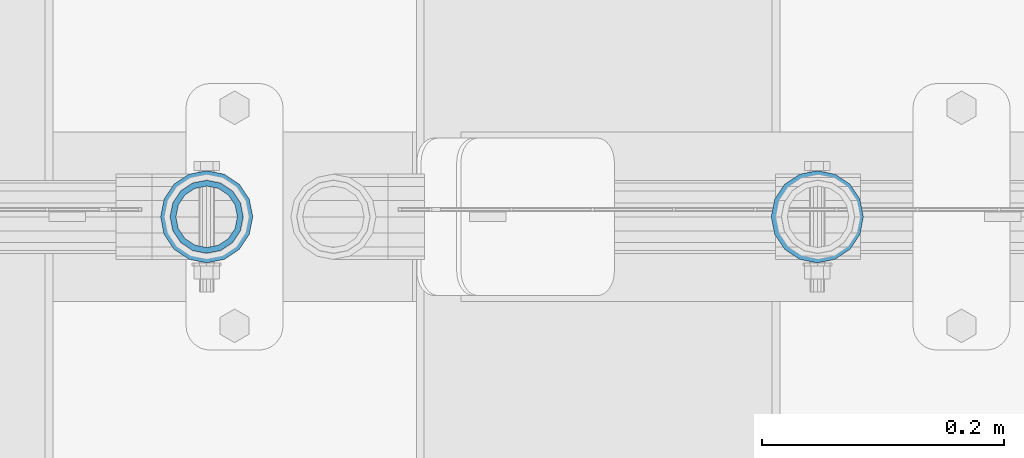
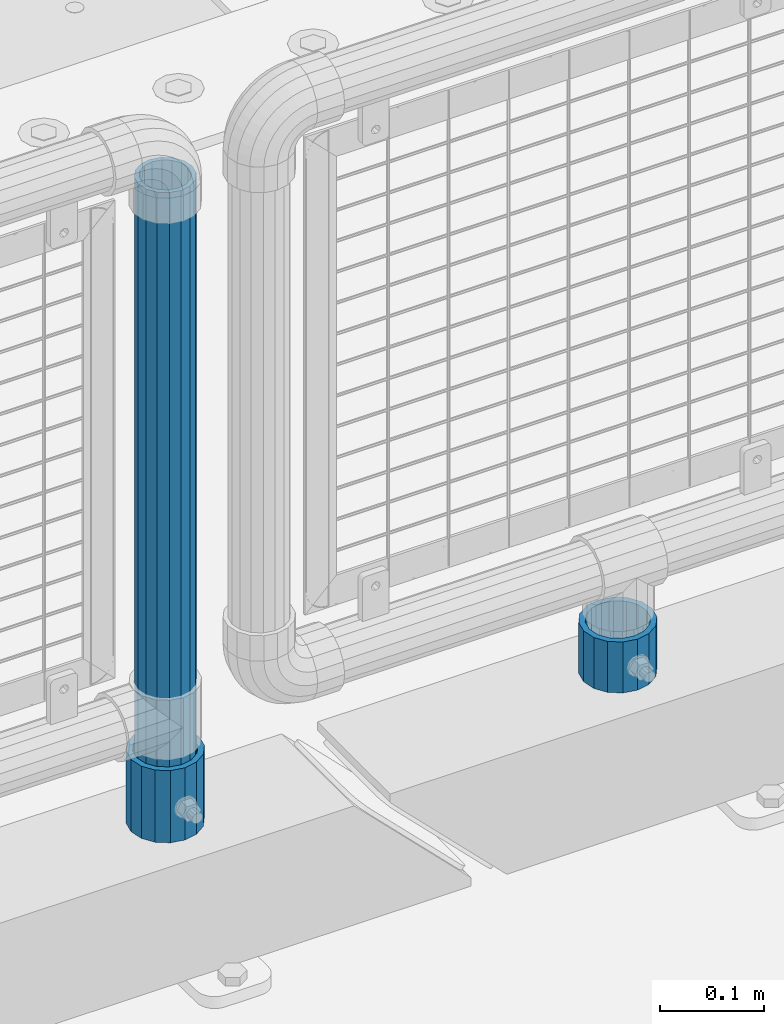
# One storey, part 90 of 219: 3 columns.
"""IFC2X3 building model written with IfcOpenShell, lengths in millimetres."""

from ifc_helpers import new_model, si_unit, frame, origin_with_axes, place, context, subcontext, project, spatial, faceted_brep, material, type_object, element, save


model = new_model("IFC2X3")

# Units and contexts
model_context = context("Model", 3, precision=1e-05, world=origin_with_axes())
body_context = subcontext(model_context, "Body", "Model", "MODEL_VIEW")
ifc_project = project(units=[si_unit("LENGTHUNIT", "METRE", prefix="MILLI"), si_unit("AREAUNIT", "SQUARE_METRE"), si_unit("VOLUMEUNIT", "CUBIC_METRE"), si_unit("MASSUNIT", "GRAM", prefix="KILO"), si_unit("TIMEUNIT", "SECOND"), si_unit("PLANEANGLEUNIT", "RADIAN"), si_unit("SOLIDANGLEUNIT", "STERADIAN"), si_unit("THERMODYNAMICTEMPERATUREUNIT", "DEGREE_CELSIUS"), si_unit("LUMINOUSINTENSITYUNIT", "LUMEN")], contexts=[model_context])

# Site, building, storey
site_placement = place(None, origin_with_axes())
site = spatial("IfcSite", under=ifc_project, at=site_placement, CompositionType="ELEMENT")
building_placement = place(site_placement, origin_with_axes())
building = spatial("IfcBuilding", under=site, at=building_placement, Name="Standard", CompositionType="ELEMENT")
storey_placement = place(building_placement, origin_with_axes())
storey = spatial("IfcBuildingStorey", under=building, at=storey_placement, Name="Undefined", CompositionType="ELEMENT", Elevation=0.0)

# Columns
ifc_material = material()
column_type_1 = type_object("IfcColumnType", PredefinedType="NOTDEFINED")
column_1_placement = place(storey_placement, frame((12227.0, 31664.5, 168.02), z_axis=(-1.0, 0.0, 0.0), x_axis=(0.0, 0.0, 1.0)))
element("IfcColumn", 1, at=column_1_placement, inside=storey, type_object=column_type_1, material=ifc_material, context=body_context, shape_type="Brep", body=[
    faceted_brep([(0.0, -25.3499999999985, 0.0), (0.0, -23.4203461491597, 9.70102501045585), (760.0, -23.4203461491597, 9.70102501045585), (760.0, -25.3499999999985, 0.0), (0.0, -17.9251569030785, 17.9251569030785), (760.0, -17.9251569030785, 17.9251569030785), (0.0, -9.70102501045403, 23.4203461491616), (760.0, -9.70102501045403, 23.4203461491616), (0.0, 0.0, 25.3500000000004), (760.0, 0.0, 25.3500000000004), (0.0, 9.70102501045403, 23.4203461491616), (760.0, 9.70102501045403, 23.4203461491616), (0.0, 17.9251569030785, 17.9251569030785), (760.0, 17.9251569030785, 17.9251569030785), (0.0, 23.4203461491597, 9.70102501045585), (760.0, 23.4203461491597, 9.70102501045585), (0.0, 25.3499999999985, 0.0), (760.0, 25.3499999999985, 0.0), (0.0, 23.4203461491597, -9.70102501045585), (760.0, 23.4203461491597, -9.70102501045585), (0.0, 17.9251569030785, -17.9251569030785), (760.0, 17.9251569030785, -17.9251569030785), (0.0, 9.70102501045403, -23.4203461491616), (760.0, 9.70102501045403, -23.4203461491616), (0.0, 0.0, -25.3500000000004), (760.0, 0.0, -25.3500000000004), (0.0, -9.70102501045403, -23.4203461491616), (760.0, -9.70102501045403, -23.4203461491616), (0.0, -17.9251569030785, -17.9251569030785), (760.0, -17.9251569030785, -17.9251569030785), (0.0, -23.4203461491597, -9.70102501045585), (760.0, -23.4203461491597, -9.70102501045585), (0.0, -30.1500000000015, 0.0), (0.0, -27.8549679052157, -11.5379054858076), (760.0, -27.8549679052157, -11.5379054858076), (760.0, -30.1500000000015, 0.0), (0.0, -21.3192694527752, -21.3192694527752), (760.0, -21.3192694527752, -21.3192694527752), (0.0, -11.5379054858058, -27.8549679052157), (760.0, -11.5379054858058, -27.8549679052157), (0.0, 0.0, -30.1499999999996), (760.0, 0.0, -30.1499999999996), (0.0, 11.5379054858058, -27.8549679052157), (760.0, 11.5379054858058, -27.8549679052157), (0.0, 21.3192694527752, -21.3192694527752), (760.0, 21.3192694527752, -21.3192694527752), (0.0, 27.8549679052157, -11.5379054858076), (760.0, 27.8549679052157, -11.5379054858076), (0.0, 30.1500000000015, 0.0), (760.0, 30.1500000000015, 0.0), (0.0, 27.8549679052157, 11.5379054858076), (760.0, 27.8549679052157, 11.5379054858076), (0.0, 21.3192694527752, 21.3192694527752), (760.0, 21.3192694527752, 21.3192694527752), (0.0, 11.5379054858058, 27.8549679052157), (760.0, 11.5379054858058, 27.8549679052157), (0.0, 0.0, 30.1499999999996), (760.0, 0.0, 30.1499999999996), (0.0, -11.5379054858058, 27.8549679052157), (760.0, -11.5379054858058, 27.8549679052157), (0.0, -21.3192694527752, 21.3192694527752), (760.0, -21.3192694527752, 21.3192694527752), (0.0, -27.8549679052157, 11.5379054858076), (760.0, -27.8549679052157, 11.5379054858076)], [[[0, 1, 2, 3]], [[1, 4, 5, 2]], [[4, 6, 7, 5]], [[6, 8, 9, 7]], [[8, 10, 11, 9]], [[10, 12, 13, 11]], [[12, 14, 15, 13]], [[14, 16, 17, 15]], [[16, 18, 19, 17]], [[18, 20, 21, 19]], [[20, 22, 23, 21]], [[22, 24, 25, 23]], [[24, 26, 27, 25]], [[26, 28, 29, 27]], [[28, 30, 31, 29]], [[30, 0, 3, 31]], [[32, 33, 34, 35]], [[33, 36, 37, 34]], [[36, 38, 39, 37]], [[38, 40, 41, 39]], [[40, 42, 43, 41]], [[42, 44, 45, 43]], [[44, 46, 47, 45]], [[46, 48, 49, 47]], [[48, 50, 51, 49]], [[50, 52, 53, 51]], [[52, 54, 55, 53]], [[54, 56, 57, 55]], [[56, 58, 59, 57]], [[58, 60, 61, 59]], [[60, 62, 63, 61]], [[62, 32, 35, 63]], [[37, 39, 41, 43, 45, 47, 49, 51, 53, 55, 57, 59, 61, 63, 35, 34], [5, 7, 9, 11, 13, 15, 17, 19, 21, 23, 25, 27, 29, 31, 3, 2]], [[62, 60, 58, 56, 54, 52, 50, 48, 46, 44, 42, 40, 38, 36, 33, 32], [30, 28, 26, 24, 22, 20, 18, 16, 14, 12, 10, 8, 6, 4, 1, 0]]]),
])
column_type_2 = type_object("IfcColumnType", PredefinedType="NOTDEFINED")
column_2_placement = place(storey_placement, frame((12227.0, 31664.5, 168.02), z_axis=(0.0, 1.0, 0.0), x_axis=(0.0, 0.0, 1.0)))
element("IfcColumn", 2, at=column_2_placement, inside=storey, type_object=column_type_2, material=ifc_material, context=body_context, shape_type="Brep", body=[
    faceted_brep([(0.0, -31.75, 0.0), (0.0, -29.3331751572332, 12.1501989775934), (85.0, -29.3331751572332, 12.1501989775934), (85.0, -31.75, 0.0), (0.0, -22.4506403026735, 22.4506403026717), (85.0, -22.4506403026735, 22.4506403026717), (0.0, -12.1501989775916, 29.3331751572332), (85.0, -12.1501989775916, 29.3331751572332), (0.0, 0.0, 31.75), (85.0, 0.0, 31.75), (0.0, 12.1501989775916, 29.3331751572332), (85.0, 12.1501989775916, 29.3331751572332), (0.0, 22.4506403026735, 22.4506403026717), (85.0, 22.4506403026735, 22.4506403026717), (0.0, 29.3331751572332, 12.1501989775934), (85.0, 29.3331751572332, 12.1501989775934), (0.0, 31.75, 0.0), (85.0, 31.75, 0.0), (0.0, 29.3331751572332, -12.1501989775934), (85.0, 29.3331751572332, -12.1501989775934), (0.0, 22.4506403026735, -22.4506403026717), (85.0, 22.4506403026735, -22.4506403026717), (0.0, 12.1501989775916, -29.3331751572332), (85.0, 12.1501989775916, -29.3331751572332), (0.0, 0.0, -31.75), (85.0, 0.0, -31.75), (0.0, -12.1501989775916, -29.3331751572332), (85.0, -12.1501989775916, -29.3331751572332), (0.0, -22.4506403026735, -22.4506403026717), (85.0, -22.4506403026735, -22.4506403026717), (0.0, -29.3331751572332, -12.1501989775934), (85.0, -29.3331751572332, -12.1501989775934), (0.0, -38.0499999999993, 0.0), (0.0, -35.1536162120537, -14.5611046014928), (85.0, -35.1536162120537, -14.5611046014928), (85.0, -38.0499999999993, 0.0), (0.0, -26.9054130241475, -26.9054130241493), (85.0, -26.9054130241475, -26.9054130241493), (0.0, -14.561104601491, -35.1536162120537), (85.0, -14.561104601491, -35.1536162120537), (0.0, 0.0, -38.0499999999993), (85.0, 0.0, -38.0499999999993), (0.0, 14.561104601491, -35.1536162120537), (85.0, 14.561104601491, -35.1536162120537), (0.0, 26.9054130241475, -26.9054130241493), (85.0, 26.9054130241475, -26.9054130241493), (0.0, 35.1536162120537, -14.5611046014928), (85.0, 35.1536162120537, -14.5611046014928), (0.0, 38.0499999999993, 0.0), (85.0, 38.0499999999993, 0.0), (0.0, 35.1536162120537, 14.5611046014928), (85.0, 35.1536162120537, 14.5611046014928), (0.0, 26.9054130241475, 26.9054130241493), (85.0, 26.9054130241475, 26.9054130241493), (0.0, 14.561104601491, 35.1536162120537), (85.0, 14.561104601491, 35.1536162120537), (0.0, 0.0, 38.0499999999993), (85.0, 0.0, 38.0499999999993), (0.0, -14.561104601491, 35.1536162120537), (85.0, -14.561104601491, 35.1536162120537), (0.0, -26.9054130241475, 26.9054130241493), (85.0, -26.9054130241475, 26.9054130241493), (0.0, -35.1536162120537, 14.5611046014928), (85.0, -35.1536162120537, 14.5611046014928)], [[[0, 1, 2, 3]], [[1, 4, 5, 2]], [[4, 6, 7, 5]], [[6, 8, 9, 7]], [[8, 10, 11, 9]], [[10, 12, 13, 11]], [[12, 14, 15, 13]], [[14, 16, 17, 15]], [[16, 18, 19, 17]], [[18, 20, 21, 19]], [[20, 22, 23, 21]], [[22, 24, 25, 23]], [[24, 26, 27, 25]], [[26, 28, 29, 27]], [[28, 30, 31, 29]], [[30, 0, 3, 31]], [[32, 33, 34, 35]], [[33, 36, 37, 34]], [[36, 38, 39, 37]], [[38, 40, 41, 39]], [[40, 42, 43, 41]], [[42, 44, 45, 43]], [[44, 46, 47, 45]], [[46, 48, 49, 47]], [[48, 50, 51, 49]], [[50, 52, 53, 51]], [[52, 54, 55, 53]], [[54, 56, 57, 55]], [[56, 58, 59, 57]], [[58, 60, 61, 59]], [[60, 62, 63, 61]], [[62, 32, 35, 63]], [[37, 39, 41, 43, 45, 47, 49, 51, 53, 55, 57, 59, 61, 63, 35, 34], [5, 7, 9, 11, 13, 15, 17, 19, 21, 23, 25, 27, 29, 31, 3, 2]], [[62, 60, 58, 56, 54, 52, 50, 48, 46, 44, 42, 40, 38, 36, 33, 32], [30, 28, 26, 24, 22, 20, 18, 16, 14, 12, 10, 8, 6, 4, 1, 0]]]),
])
column_3_placement = place(storey_placement, frame((12731.0, 31664.5, 168.019999999998), z_axis=(0.0, 1.0, 0.0), x_axis=(0.0, 0.0, 1.0)))
element("IfcColumn", 3, at=column_3_placement, inside=storey, type_object=column_type_2, material=ifc_material, context=body_context, shape_type="Brep", body=[
    faceted_brep([(0.0, -31.75, 0.0), (0.0, -29.3331751572332, 12.1501989775934), (60.0, -29.3331751572332, 12.1501989775934), (60.0, -31.75, 0.0), (0.0, -22.4506403026735, 22.4506403026717), (60.0, -22.4506403026735, 22.4506403026717), (0.0, -12.1501989775916, 29.3331751572332), (60.0, -12.1501989775916, 29.3331751572332), (0.0, 0.0, 31.75), (60.0, 0.0, 31.75), (0.0, 12.1501989775916, 29.3331751572332), (60.0, 12.1501989775916, 29.3331751572332), (0.0, 22.4506403026735, 22.4506403026717), (60.0, 22.4506403026735, 22.4506403026717), (0.0, 29.3331751572332, 12.1501989775934), (60.0, 29.3331751572332, 12.1501989775934), (0.0, 31.75, 0.0), (60.0, 31.75, 0.0), (0.0, 29.3331751572332, -12.1501989775934), (60.0, 29.3331751572332, -12.1501989775934), (0.0, 22.4506403026735, -22.4506403026717), (60.0, 22.4506403026735, -22.4506403026717), (0.0, 12.1501989775916, -29.3331751572332), (60.0, 12.1501989775916, -29.3331751572332), (0.0, 0.0, -31.75), (60.0, 0.0, -31.75), (0.0, -12.1501989775916, -29.3331751572332), (60.0, -12.1501989775916, -29.3331751572332), (0.0, -22.4506403026735, -22.4506403026717), (60.0, -22.4506403026735, -22.4506403026717), (0.0, -29.3331751572332, -12.1501989775934), (60.0, -29.3331751572332, -12.1501989775934), (0.0, -38.0499999999993, 0.0), (0.0, -35.1536162120537, -14.5611046014928), (60.0, -35.1536162120537, -14.5611046014928), (60.0, -38.0499999999993, 0.0), (0.0, -26.9054130241475, -26.9054130241493), (60.0, -26.9054130241475, -26.9054130241493), (0.0, -14.561104601491, -35.1536162120537), (60.0, -14.561104601491, -35.1536162120537), (0.0, 0.0, -38.0499999999993), (60.0, 0.0, -38.0499999999993), (0.0, 14.561104601491, -35.1536162120537), (60.0, 14.561104601491, -35.1536162120537), (0.0, 26.9054130241475, -26.9054130241493), (60.0, 26.9054130241475, -26.9054130241493), (0.0, 35.1536162120537, -14.5611046014928), (60.0, 35.1536162120537, -14.5611046014928), (0.0, 38.0499999999993, 0.0), (60.0, 38.0499999999993, 0.0), (0.0, 35.1536162120537, 14.5611046014928), (60.0, 35.1536162120537, 14.5611046014928), (0.0, 26.9054130241475, 26.9054130241493), (60.0, 26.9054130241475, 26.9054130241493), (0.0, 14.561104601491, 35.1536162120537), (60.0, 14.561104601491, 35.1536162120537), (0.0, 0.0, 38.0499999999993), (60.0, 0.0, 38.0499999999993), (0.0, -14.561104601491, 35.1536162120537), (60.0, -14.561104601491, 35.1536162120537), (0.0, -26.9054130241475, 26.9054130241493), (60.0, -26.9054130241475, 26.9054130241493), (0.0, -35.1536162120537, 14.5611046014928), (60.0, -35.1536162120537, 14.5611046014928)], [[[0, 1, 2, 3]], [[1, 4, 5, 2]], [[4, 6, 7, 5]], [[6, 8, 9, 7]], [[8, 10, 11, 9]], [[10, 12, 13, 11]], [[12, 14, 15, 13]], [[14, 16, 17, 15]], [[16, 18, 19, 17]], [[18, 20, 21, 19]], [[20, 22, 23, 21]], [[22, 24, 25, 23]], [[24, 26, 27, 25]], [[26, 28, 29, 27]], [[28, 30, 31, 29]], [[30, 0, 3, 31]], [[32, 33, 34, 35]], [[33, 36, 37, 34]], [[36, 38, 39, 37]], [[38, 40, 41, 39]], [[40, 42, 43, 41]], [[42, 44, 45, 43]], [[44, 46, 47, 45]], [[46, 48, 49, 47]], [[48, 50, 51, 49]], [[50, 52, 53, 51]], [[52, 54, 55, 53]], [[54, 56, 57, 55]], [[56, 58, 59, 57]], [[58, 60, 61, 59]], [[60, 62, 63, 61]], [[62, 32, 35, 63]], [[37, 39, 41, 43, 45, 47, 49, 51, 53, 55, 57, 59, 61, 63, 35, 34], [5, 7, 9, 11, 13, 15, 17, 19, 21, 23, 25, 27, 29, 31, 3, 2]], [[62, 60, 58, 56, 54, 52, 50, 48, 46, 44, 42, 40, 38, 36, 33, 32], [30, 28, 26, 24, 22, 20, 18, 16, 14, 12, 10, 8, 6, 4, 1, 0]]]),
])

save(model, "model.ifc")
